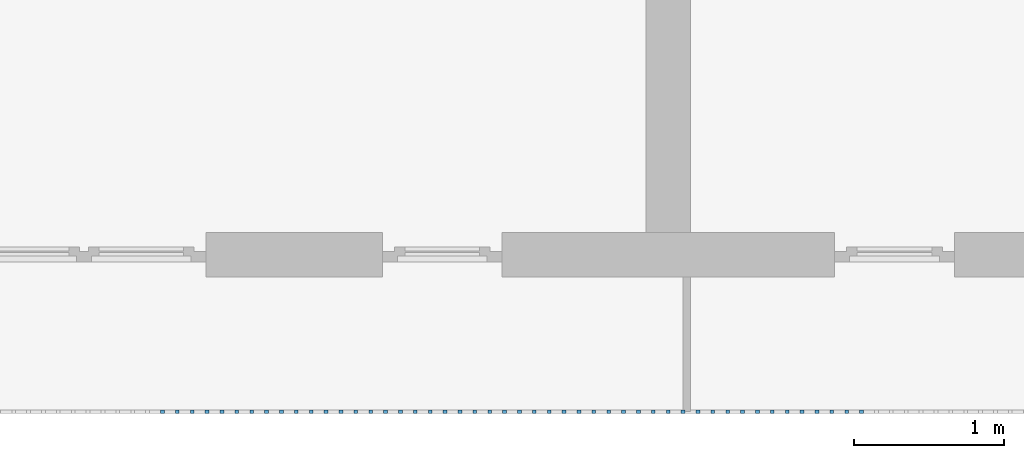
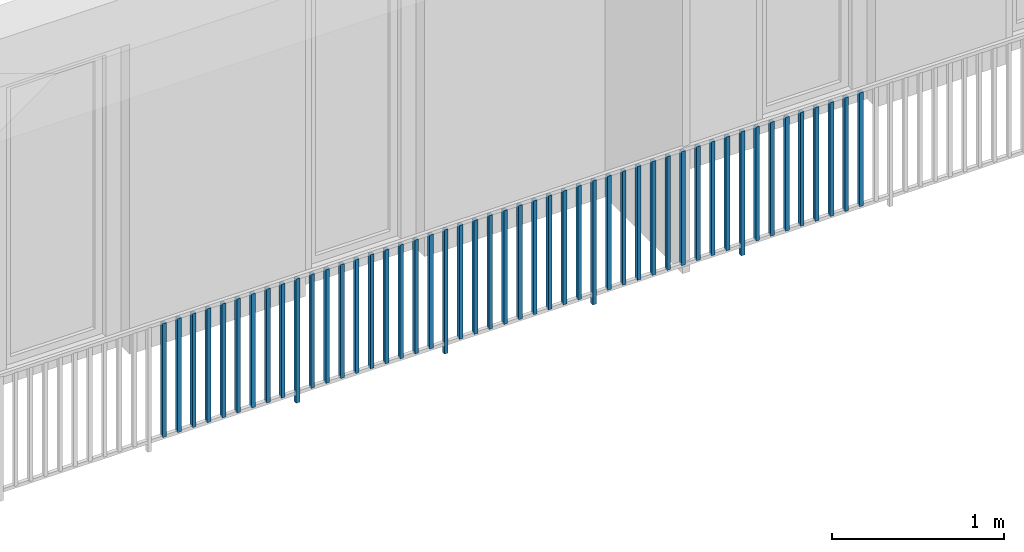
# One storey, part 35 of 54: 48 building element parts, 1 element without a shape of its own.
"""IFC4 building model written with IfcOpenShell, lengths in metres."""

import ifcopenshell
import ifcopenshell.guid

model = None  # the IFC model being written
_history = None  # IfcOwnerHistory: only IFC2X3 demands one
_inside = {}  # id of a spatial element -> (the spatial element, [elements in it])
_under = {}  # id of a project, library or spatial element -> (it, [spatial elements below it])
_declared = {}  # id of a project -> (the project, [libraries it declares])
_typed = {}  # id of a type object -> (the type object, [elements of that type])
_made_of = {}  # id of a material, layer set ... -> (it, [elements and type objects made of it])


def new_model(schema):
    """Start an empty IFC model of exactly this schema.

    Asked for "IFC4X3", IfcOpenShell would pick the latest addendum, in which some entities
    have other attributes; the version numbers below select the first issue.
    IFC2X3 requires an IfcOwnerHistory on every rooted entity: one is made here for all.
    """
    global model, _history
    if schema == "IFC4X3":
        model = ifcopenshell.file(schema_version=(4, 3, 0, 0))
    else:
        model = ifcopenshell.file(schema=schema)
    _inside.clear()
    _under.clear()
    _declared.clear()
    _typed.clear()
    _made_of.clear()
    _history = None
    if model.schema == "IFC2X3":
        org = make("IfcOrganization", Name="unknown")
        user = make(
            "IfcPersonAndOrganization",
            ThePerson=make("IfcPerson", FamilyName="unknown"),
            TheOrganization=org,
        )
        app = make(
            "IfcApplication",
            ApplicationDeveloper=org,
            Version="unknown",
            ApplicationFullName="unknown",
            ApplicationIdentifier="unknown",
        )
        _history = make(
            "IfcOwnerHistory",
            OwningUser=user,
            OwningApplication=app,
            ChangeAction="ADDED",
            CreationDate=0,
        )
    return model


def make(cls, **values):
    """One entity of the class cls with the attributes given. An attribute that is None is left unset."""
    return model.create_entity(
        cls, **{name: value for name, value in values.items() if value is not None}
    )


def entity(cls, *values):
    """Any entity or typed value of the class cls, its attributes in the order of the schema. None: left unset."""
    e = model.create_entity(cls)
    for i, value in enumerate(values):
        if value is not None:
            e[i] = value
    return e


def rooted(cls, **values):
    """An entity with a GlobalId (a new one), such as an element, a storey or a relation."""
    return make(cls, GlobalId=ifcopenshell.guid.new(), OwnerHistory=_history, **values)


def si_unit(unit_type, name, prefix=None):
    """IfcSIUnit, for example si_unit("LENGTHUNIT", "METRE", prefix="MILLI")."""
    return make("IfcSIUnit", UnitType=unit_type, Prefix=prefix, Name=name)


def converted_unit(unit_type, name, factor, base, dimensions=None, offset=None):
    """IfcConversionBasedUnit, such as the inch: factor (a typed value) times the base unit."""
    return make(
        "IfcConversionBasedUnit"
        if offset is None
        else "IfcConversionBasedUnitWithOffset",
        ConversionOffset=offset,
        Dimensions=None
        if dimensions is None
        else entity("IfcDimensionalExponents", *dimensions),
        UnitType=unit_type,
        Name=name,
        ConversionFactor=make(
            "IfcMeasureWithUnit", ValueComponent=factor, UnitComponent=base
        ),
    )


def derived_unit(unit_type, elements):
    """IfcDerivedUnit: a product of units, each with its exponent."""
    return make(
        "IfcDerivedUnit",
        Elements=[
            make("IfcDerivedUnitElement", Unit=unit, Exponent=power)
            for unit, power in elements
        ],
        UnitType=unit_type,
    )


def assignment(units):
    """IfcUnitAssignment: the units of a project."""
    return None if units is None else make("IfcUnitAssignment", Units=units)


def point(xyz):
    """IfcCartesianPoint."""
    return None if xyz is None else make("IfcCartesianPoint", Coordinates=xyz)


def direction(xyz):
    """IfcDirection."""
    return None if xyz is None else make("IfcDirection", DirectionRatios=xyz)


def frame(location, z_axis=None, x_axis=None):
    """IfcAxis2Placement3D, a coordinate frame: its origin and axes. An axis left out is left unset."""
    return make(
        "IfcAxis2Placement3D",
        Location=point(location),
        Axis=direction(z_axis),
        RefDirection=direction(x_axis),
    )


def origin_with_axes():
    """The frame at (0, 0, 0) with the z axis (0, 0, 1) and the x axis (1, 0, 0) written out."""
    return frame((0.0, 0.0, 0.0), z_axis=(0.0, 0.0, 1.0), x_axis=(1.0, 0.0, 0.0))


def place(relative_to, where):
    """IfcLocalPlacement: puts the frame where relative to a parent placement (None: the world)."""
    return make(
        "IfcLocalPlacement", PlacementRelTo=relative_to, RelativePlacement=where
    )


def context(
    kind, dimensions, precision=None, world=None, true_north=None, identifier=None
):
    """IfcGeometricRepresentationContext, for example the 3D "Model" context."""
    return make(
        "IfcGeometricRepresentationContext",
        ContextIdentifier=identifier,
        ContextType=kind,
        CoordinateSpaceDimension=dimensions,
        Precision=precision,
        WorldCoordinateSystem=world,
        TrueNorth=true_north,
    )


def subcontext(parent, identifier, kind, view, scale=None):
    """IfcGeometricRepresentationSubContext, for example "Body" below "Model"."""
    return make(
        "IfcGeometricRepresentationSubContext",
        ContextIdentifier=identifier,
        ContextType=kind,
        ParentContext=parent,
        TargetScale=scale,
        TargetView=view,
    )


def project(units=None, contexts=None):
    """IfcProject with its units and contexts."""
    return rooted(
        "IfcProject",
        Name="project",
        RepresentationContexts=contexts,
        UnitsInContext=assignment(units),
    )


def spatial(cls, under=None, at=None, **own):
    """A site, building, storey or space (cls), placed at a placement, below another one or the project."""
    s = rooted(cls, ObjectPlacement=at, **own)
    if under is not None:
        _under.setdefault(under.id(), (under, []))[1].append(s)
    return s


def point_list(points):
    """IfcCartesianPointList2D or 3D."""
    cls = (
        "IfcCartesianPointList2D" if len(points[0]) == 2 else "IfcCartesianPointList3D"
    )
    return make(cls, CoordList=points)


def polygons(points, faces, closed=None, point_numbers=None):
    """IfcPolygonalFaceSet: a face is its outer loop, then its inner loops; points numbered from 1."""
    made = []
    for loops in faces:
        if len(loops) == 1:
            made.append(make("IfcIndexedPolygonalFace", CoordIndex=loops[0]))
        else:
            made.append(
                make(
                    "IfcIndexedPolygonalFaceWithVoids",
                    CoordIndex=loops[0],
                    InnerCoordIndices=loops[1:],
                )
            )
    return make(
        "IfcPolygonalFaceSet",
        Coordinates=point_list(points),
        Closed=closed,
        Faces=made,
        PnIndex=point_numbers,
    )


def shape(context_of_items, identifier, shape_type, items):
    """IfcShapeRepresentation: the items that make up one representation, for example the "Body"."""
    return make(
        "IfcShapeRepresentation",
        ContextOfItems=context_of_items,
        RepresentationIdentifier=identifier,
        RepresentationType=shape_type,
        Items=items,
    )


def material(Name=None, Category=None):
    """IfcMaterial."""
    return make("IfcMaterial", Name=Name, Category=Category)


def made_of(thing, what):
    """Note that an element or type object is made of a material, layer set ...; save() writes the relation."""
    if what is not None:
        _made_of.setdefault(what.id(), (what, []))[1].append(thing)
    return thing


def type_object(cls, material=None, **own):
    """A type object (cls), such as IfcWallType, which elements share."""
    return made_of(rooted(cls, **own), material)


def element(
    cls,
    number,
    at=None,
    inside=None,
    cuts=None,
    type_object=None,
    material=None,
    context=None,
    identifier="Body",
    shape_type=None,
    held_by="IfcProductDefinitionShape",
    body=None,
    shapes=None,
    **own,
):
    """One element of the class cls, such as IfcWall. Its Tag is "e" and its number.

    at: its placement. inside: the storey or other place that contains it. cuts: it is an
    opening in that element (IfcRelVoidsElement). A single representation is given by context,
    identifier, shape_type and body (its items); several are given by shapes. held_by: the class
    of the entity that holds the representations. save() writes the other relations.
    """
    e = rooted(cls, Tag="e%d" % number, ObjectPlacement=at, **own)
    if body is not None:
        shapes = [shape(context, identifier, shape_type, body)]
    if shapes is not None:
        e.Representation = make(held_by, Representations=shapes)
    if inside is not None:
        _inside.setdefault(inside.id(), (inside, []))[1].append(e)
    if cuts is not None:
        rooted(
            "IfcRelVoidsElement", RelatingBuildingElement=cuts, RelatedOpeningElement=e
        )
    if type_object is not None:
        _typed.setdefault(type_object.id(), (type_object, []))[1].append(e)
    return made_of(e, material)


def aggregate(whole, parts):
    """IfcRelAggregates: a whole, such as a stair, and the parts it consists of."""
    return rooted("IfcRelAggregates", RelatingObject=whole, RelatedObjects=parts)


def save(model, path):
    """Write the relations noted so far, then the file.

    IfcRelAggregates (storeys below a building ...), IfcRelContainedInSpatialStructure (elements
    in a storey), IfcRelDefinesByType, IfcRelAssociatesMaterial and IfcRelDeclares: one each for
    every whole, place, type object, material and project.
    """
    for whole, parts in _under.values():
        aggregate(whole, parts)
    for where, things in _inside.values():
        rooted(
            "IfcRelContainedInSpatialStructure",
            RelatedElements=things,
            RelatingStructure=where,
        )
    for kind, things in _typed.values():
        rooted("IfcRelDefinesByType", RelatedObjects=things, RelatingType=kind)
    for what, things in _made_of.values():
        rooted("IfcRelAssociatesMaterial", RelatedObjects=things, RelatingMaterial=what)
    for by, libraries in _declared.values():
        rooted("IfcRelDeclares", RelatingContext=by, RelatedDefinitions=libraries)
    model.write(path)


model = new_model("IFC4")

# Units and contexts
model_context = context("Model", 3, precision=1e-05, world=origin_with_axes(), true_north=direction((0.0, 1.0)))
body_context = subcontext(model_context, "Body", "Model", "MODEL_VIEW")
ifc_project = project(units=[si_unit("LENGTHUNIT", "METRE"), si_unit("AREAUNIT", "SQUARE_METRE"), si_unit("VOLUMEUNIT", "CUBIC_METRE"), converted_unit("PLANEANGLEUNIT", "DEGREE", entity("IfcPlaneAngleMeasure", 0.0174532925199), si_unit("PLANEANGLEUNIT", "RADIAN"), dimensions=[0, 0, 0, 0, 0, 0, 0]), converted_unit("TIMEUNIT", "Year", entity("IfcTimeMeasure", 31556926.0), si_unit("TIMEUNIT", "SECOND"), dimensions=[0, 0, 1, 0, 0, 0, 0]), si_unit("MASSUNIT", "GRAM", prefix="KILO"), si_unit("THERMODYNAMICTEMPERATUREUNIT", "DEGREE_CELSIUS"), si_unit("LUMINOUSINTENSITYUNIT", "LUMEN"), si_unit("ENERGYUNIT", "JOULE", prefix="MEGA"), derived_unit("THERMALCONDUCTANCEUNIT", [(si_unit("POWERUNIT", "WATT"), 1), (si_unit("LENGTHUNIT", "METRE"), -1), (si_unit("THERMODYNAMICTEMPERATUREUNIT", "KELVIN"), -1)]), derived_unit("SPECIFICHEATCAPACITYUNIT", [(si_unit("ENERGYUNIT", "JOULE"), 1), (si_unit("MASSUNIT", "GRAM", prefix="KILO"), -1), (si_unit("THERMODYNAMICTEMPERATUREUNIT", "KELVIN"), -1)]), derived_unit("MASSDENSITYUNIT", [(si_unit("MASSUNIT", "GRAM", prefix="KILO"), 1), (si_unit("VOLUMEUNIT", "CUBIC_METRE"), -1)])], contexts=[model_context])

# Site, building, storey, space
site_placement = place(None, origin_with_axes())
site = spatial("IfcSite", under=ifc_project, at=site_placement, CompositionType="ELEMENT")
building_placement = place(site_placement, origin_with_axes())
building = spatial("IfcBuilding", under=site, at=building_placement, CompositionType="ELEMENT")
storey_placement = place(building_placement, frame((0.0, 0.0, 6.29), z_axis=(0.0, 0.0, 1.0), x_axis=(1.0, 0.0, 0.0)))
storey = spatial("IfcBuildingStorey", under=building, at=storey_placement, Name="2. Geschoss", CompositionType="ELEMENT", Elevation=6.29)
space_placement = place(storey_placement, frame((10.2378006196, 9.82118769833, 0.0), z_axis=(0.0, 0.0, 1.0), x_axis=(-1.0, 0.0, 0.0)))
space = spatial("IfcSpace", under=storey, at=space_placement, CompositionType="ELEMENT", PredefinedType="EXTERNAL")

# Railing, building element parts
railing_type = type_object("IfcRailingType", PredefinedType="NOTDEFINED")
railing_placement = place(space_placement, frame((0.0, -7.06315681498e-08, 0.0), z_axis=(0.0, 0.0, 1.0), x_axis=(-1.0, 0.0, 0.0)))
railing = element("IfcRailing", 1, at=railing_placement, inside=space, type_object=railing_type, PredefinedType="NOTDEFINED")
ifc_material = material()
building_element_part_1_placement = place(railing_placement, origin_with_axes())
building_element_part_1 = element("IfcBuildingElementPart", 2, at=building_element_part_1_placement, material=ifc_material, PredefinedType="NOTDEFINED", context=body_context, shape_type="Tessellation", body=[
    polygons([(-14.8097608696, -20.6625, 0.07), (-14.8097608696, -20.6375, 0.07), (-14.8097608696, -20.6375, 0.8775), (-14.8097608696, -20.6625, 0.8775), (-14.8347608696, -20.6625, 0.07), (-14.8347608696, -20.6375, 0.07), (-14.8347608696, -20.6375, 0.8775), (-14.8347608696, -20.6625, 0.8775)], [[[1, 2, 3, 4]], [[1, 5, 6, 2]], [[2, 6, 7, 3]], [[4, 3, 7, 8]], [[5, 1, 4, 8]], [[6, 5, 8, 7]]], closed=True),
])
building_element_part_2_placement = place(railing_placement, origin_with_axes())
building_element_part_2 = element("IfcBuildingElementPart", 3, at=building_element_part_2_placement, material=ifc_material, PredefinedType="NOTDEFINED", context=body_context, shape_type="Tessellation", body=[
    polygons([(-14.7102826087, -20.6625, 0.07), (-14.7102826087, -20.6375, 0.07), (-14.7102826087, -20.6375, 0.8775), (-14.7102826087, -20.6625, 0.8775), (-14.7352826087, -20.6625, 0.07), (-14.7352826087, -20.6375, 0.07), (-14.7352826087, -20.6375, 0.8775), (-14.7352826087, -20.6625, 0.8775)], [[[1, 2, 3, 4]], [[1, 5, 6, 2]], [[2, 6, 7, 3]], [[4, 3, 7, 8]], [[5, 1, 4, 8]], [[6, 5, 8, 7]]], closed=True),
])
building_element_part_3_placement = place(railing_placement, origin_with_axes())
building_element_part_3 = element("IfcBuildingElementPart", 4, at=building_element_part_3_placement, material=ifc_material, PredefinedType="NOTDEFINED", context=body_context, shape_type="Tessellation", body=[
    polygons([(-14.6108043478, -20.6625, 0.07), (-14.6108043478, -20.6375, 0.07), (-14.6108043478, -20.6375, 0.8775), (-14.6108043478, -20.6625, 0.8775), (-14.6358043478, -20.6625, 0.07), (-14.6358043478, -20.6375, 0.07), (-14.6358043478, -20.6375, 0.8775), (-14.6358043478, -20.6625, 0.8775)], [[[1, 2, 3, 4]], [[1, 5, 6, 2]], [[2, 6, 7, 3]], [[4, 3, 7, 8]], [[5, 1, 4, 8]], [[6, 5, 8, 7]]], closed=True),
])
building_element_part_4_placement = place(railing_placement, origin_with_axes())
building_element_part_4 = element("IfcBuildingElementPart", 5, at=building_element_part_4_placement, material=ifc_material, PredefinedType="NOTDEFINED", context=body_context, shape_type="Tessellation", body=[
    polygons([(-14.511326087, -20.6625, 0.07), (-14.511326087, -20.6375, 0.07), (-14.511326087, -20.6375, 0.8775), (-14.511326087, -20.6625, 0.8775), (-14.536326087, -20.6625, 0.07), (-14.536326087, -20.6375, 0.07), (-14.536326087, -20.6375, 0.8775), (-14.536326087, -20.6625, 0.8775)], [[[1, 2, 3, 4]], [[1, 5, 6, 2]], [[2, 6, 7, 3]], [[4, 3, 7, 8]], [[5, 1, 4, 8]], [[6, 5, 8, 7]]], closed=True),
])
building_element_part_5_placement = place(railing_placement, origin_with_axes())
building_element_part_5 = element("IfcBuildingElementPart", 6, at=building_element_part_5_placement, material=ifc_material, PredefinedType="NOTDEFINED", context=body_context, shape_type="Tessellation", body=[
    polygons([(-14.4118478261, -20.6625, 0.07), (-14.4118478261, -20.6375, 0.07), (-14.4118478261, -20.6375, 0.8775), (-14.4118478261, -20.6625, 0.8775), (-14.4368478261, -20.6625, 0.07), (-14.4368478261, -20.6375, 0.07), (-14.4368478261, -20.6375, 0.8775), (-14.4368478261, -20.6625, 0.8775)], [[[1, 2, 3, 4]], [[1, 5, 6, 2]], [[2, 6, 7, 3]], [[4, 3, 7, 8]], [[5, 1, 4, 8]], [[6, 5, 8, 7]]], closed=True),
])
building_element_part_6_placement = place(railing_placement, origin_with_axes())
building_element_part_6 = element("IfcBuildingElementPart", 7, at=building_element_part_6_placement, material=ifc_material, PredefinedType="NOTDEFINED", context=body_context, shape_type="Tessellation", body=[
    polygons([(-14.3123695652, -20.6625, 0.07), (-14.3123695652, -20.6375, 0.07), (-14.3123695652, -20.6375, 0.8775), (-14.3123695652, -20.6625, 0.8775), (-14.3373695652, -20.6625, 0.07), (-14.3373695652, -20.6375, 0.07), (-14.3373695652, -20.6375, 0.8775), (-14.3373695652, -20.6625, 0.8775)], [[[1, 2, 3, 4]], [[1, 5, 6, 2]], [[2, 6, 7, 3]], [[4, 3, 7, 8]], [[5, 1, 4, 8]], [[6, 5, 8, 7]]], closed=True),
])
building_element_part_7_placement = place(railing_placement, origin_with_axes())
building_element_part_7 = element("IfcBuildingElementPart", 8, at=building_element_part_7_placement, material=ifc_material, PredefinedType="NOTDEFINED", context=body_context, shape_type="Tessellation", body=[
    polygons([(-14.2128913043, -20.6625, 0.07), (-14.2128913043, -20.6375, 0.07), (-14.2128913043, -20.6375, 0.8775), (-14.2128913043, -20.6625, 0.8775), (-14.2378913043, -20.6625, 0.07), (-14.2378913043, -20.6375, 0.07), (-14.2378913043, -20.6375, 0.8775), (-14.2378913043, -20.6625, 0.8775)], [[[1, 2, 3, 4]], [[1, 5, 6, 2]], [[2, 6, 7, 3]], [[4, 3, 7, 8]], [[5, 1, 4, 8]], [[6, 5, 8, 7]]], closed=True),
])
building_element_part_8_placement = place(railing_placement, origin_with_axes())
building_element_part_8 = element("IfcBuildingElementPart", 9, at=building_element_part_8_placement, material=ifc_material, PredefinedType="NOTDEFINED", context=body_context, shape_type="Tessellation", body=[
    polygons([(-14.1134130435, -20.6625, 0.07), (-14.1134130435, -20.6375, 0.07), (-14.1134130435, -20.6375, 0.8775), (-14.1134130435, -20.6625, 0.8775), (-14.1384130435, -20.6625, 0.07), (-14.1384130435, -20.6375, 0.07), (-14.1384130435, -20.6375, 0.8775), (-14.1384130435, -20.6625, 0.8775)], [[[1, 2, 3, 4]], [[1, 5, 6, 2]], [[2, 6, 7, 3]], [[4, 3, 7, 8]], [[5, 1, 4, 8]], [[6, 5, 8, 7]]], closed=True),
])
building_element_part_9_placement = place(railing_placement, origin_with_axes())
building_element_part_9 = element("IfcBuildingElementPart", 10, at=building_element_part_9_placement, material=ifc_material, PredefinedType="NOTDEFINED", context=body_context, shape_type="Tessellation", body=[
    polygons([(-14.0139347826, -20.6625, 0.07), (-14.0139347826, -20.6375, 0.07), (-14.0139347826, -20.6375, 0.8775), (-14.0139347826, -20.6625, 0.8775), (-14.0389347826, -20.6625, 0.07), (-14.0389347826, -20.6375, 0.07), (-14.0389347826, -20.6375, 0.8775), (-14.0389347826, -20.6625, 0.8775)], [[[1, 2, 3, 4]], [[1, 5, 6, 2]], [[2, 6, 7, 3]], [[4, 3, 7, 8]], [[5, 1, 4, 8]], [[6, 5, 8, 7]]], closed=True),
])
building_element_part_10_placement = place(railing_placement, origin_with_axes())
building_element_part_10 = element("IfcBuildingElementPart", 11, at=building_element_part_10_placement, material=ifc_material, PredefinedType="NOTDEFINED", context=body_context, shape_type="Tessellation", body=[
    polygons([(-13.9144565217, -20.6625, 0.0), (-13.9144565217, -20.6375, 0.0), (-13.9144565217, -20.6375, 0.88), (-13.9144565217, -20.6625, 0.88), (-13.9394565217, -20.6625, 0.0), (-13.9394565217, -20.6375, 0.0), (-13.9394565217, -20.6375, 0.88), (-13.9394565217, -20.6625, 0.88)], [[[1, 2, 3, 4]], [[1, 5, 6, 2]], [[2, 6, 7, 3]], [[4, 3, 7, 8]], [[5, 1, 4, 8]], [[6, 5, 8, 7]]], closed=True),
])
building_element_part_11_placement = place(railing_placement, origin_with_axes())
building_element_part_11 = element("IfcBuildingElementPart", 12, at=building_element_part_11_placement, material=ifc_material, PredefinedType="NOTDEFINED", context=body_context, shape_type="Tessellation", body=[
    polygons([(-13.8149782609, -20.6625, 0.07), (-13.8149782609, -20.6375, 0.07), (-13.8149782609, -20.6375, 0.8775), (-13.8149782609, -20.6625, 0.8775), (-13.8399782609, -20.6625, 0.07), (-13.8399782609, -20.6375, 0.07), (-13.8399782609, -20.6375, 0.8775), (-13.8399782609, -20.6625, 0.8775)], [[[1, 2, 3, 4]], [[1, 5, 6, 2]], [[2, 6, 7, 3]], [[4, 3, 7, 8]], [[5, 1, 4, 8]], [[6, 5, 8, 7]]], closed=True),
])
building_element_part_12_placement = place(railing_placement, origin_with_axes())
building_element_part_12 = element("IfcBuildingElementPart", 13, at=building_element_part_12_placement, material=ifc_material, PredefinedType="NOTDEFINED", context=body_context, shape_type="Tessellation", body=[
    polygons([(-13.7155, -20.6625, 0.07), (-13.7155, -20.6375, 0.07), (-13.7155, -20.6375, 0.8775), (-13.7155, -20.6625, 0.8775), (-13.7405, -20.6625, 0.07), (-13.7405, -20.6375, 0.07), (-13.7405, -20.6375, 0.8775), (-13.7405, -20.6625, 0.8775)], [[[1, 2, 3, 4]], [[1, 5, 6, 2]], [[2, 6, 7, 3]], [[4, 3, 7, 8]], [[5, 1, 4, 8]], [[6, 5, 8, 7]]], closed=True),
])
building_element_part_13_placement = place(railing_placement, origin_with_axes())
building_element_part_13 = element("IfcBuildingElementPart", 14, at=building_element_part_13_placement, material=ifc_material, PredefinedType="NOTDEFINED", context=body_context, shape_type="Tessellation", body=[
    polygons([(-13.6160217391, -20.6625, 0.07), (-13.6160217391, -20.6375, 0.07), (-13.6160217391, -20.6375, 0.8775), (-13.6160217391, -20.6625, 0.8775), (-13.6410217391, -20.6625, 0.07), (-13.6410217391, -20.6375, 0.07), (-13.6410217391, -20.6375, 0.8775), (-13.6410217391, -20.6625, 0.8775)], [[[1, 2, 3, 4]], [[1, 5, 6, 2]], [[2, 6, 7, 3]], [[4, 3, 7, 8]], [[5, 1, 4, 8]], [[6, 5, 8, 7]]], closed=True),
])
building_element_part_14_placement = place(railing_placement, origin_with_axes())
building_element_part_14 = element("IfcBuildingElementPart", 15, at=building_element_part_14_placement, material=ifc_material, PredefinedType="NOTDEFINED", context=body_context, shape_type="Tessellation", body=[
    polygons([(-13.5165434783, -20.6625, 0.07), (-13.5165434783, -20.6375, 0.07), (-13.5165434783, -20.6375, 0.8775), (-13.5165434783, -20.6625, 0.8775), (-13.5415434783, -20.6625, 0.07), (-13.5415434783, -20.6375, 0.07), (-13.5415434783, -20.6375, 0.8775), (-13.5415434783, -20.6625, 0.8775)], [[[1, 2, 3, 4]], [[1, 5, 6, 2]], [[2, 6, 7, 3]], [[4, 3, 7, 8]], [[5, 1, 4, 8]], [[6, 5, 8, 7]]], closed=True),
])
building_element_part_15_placement = place(railing_placement, origin_with_axes())
building_element_part_15 = element("IfcBuildingElementPart", 16, at=building_element_part_15_placement, material=ifc_material, PredefinedType="NOTDEFINED", context=body_context, shape_type="Tessellation", body=[
    polygons([(-13.4170652174, -20.6625, 0.07), (-13.4170652174, -20.6375, 0.07), (-13.4170652174, -20.6375, 0.8775), (-13.4170652174, -20.6625, 0.8775), (-13.4420652174, -20.6625, 0.07), (-13.4420652174, -20.6375, 0.07), (-13.4420652174, -20.6375, 0.8775), (-13.4420652174, -20.6625, 0.8775)], [[[1, 2, 3, 4]], [[1, 5, 6, 2]], [[2, 6, 7, 3]], [[4, 3, 7, 8]], [[5, 1, 4, 8]], [[6, 5, 8, 7]]], closed=True),
])
building_element_part_16_placement = place(railing_placement, origin_with_axes())
building_element_part_16 = element("IfcBuildingElementPart", 17, at=building_element_part_16_placement, material=ifc_material, PredefinedType="NOTDEFINED", context=body_context, shape_type="Tessellation", body=[
    polygons([(-13.3175869565, -20.6625, 0.07), (-13.3175869565, -20.6375, 0.07), (-13.3175869565, -20.6375, 0.8775), (-13.3175869565, -20.6625, 0.8775), (-13.3425869565, -20.6625, 0.07), (-13.3425869565, -20.6375, 0.07), (-13.3425869565, -20.6375, 0.8775), (-13.3425869565, -20.6625, 0.8775)], [[[1, 2, 3, 4]], [[1, 5, 6, 2]], [[2, 6, 7, 3]], [[4, 3, 7, 8]], [[5, 1, 4, 8]], [[6, 5, 8, 7]]], closed=True),
])
building_element_part_17_placement = place(railing_placement, origin_with_axes())
building_element_part_17 = element("IfcBuildingElementPart", 18, at=building_element_part_17_placement, material=ifc_material, PredefinedType="NOTDEFINED", context=body_context, shape_type="Tessellation", body=[
    polygons([(-13.2181086957, -20.6625, 0.07), (-13.2181086957, -20.6375, 0.07), (-13.2181086957, -20.6375, 0.8775), (-13.2181086957, -20.6625, 0.8775), (-13.2431086957, -20.6625, 0.07), (-13.2431086957, -20.6375, 0.07), (-13.2431086957, -20.6375, 0.8775), (-13.2431086957, -20.6625, 0.8775)], [[[1, 2, 3, 4]], [[1, 5, 6, 2]], [[2, 6, 7, 3]], [[4, 3, 7, 8]], [[5, 1, 4, 8]], [[6, 5, 8, 7]]], closed=True),
])
building_element_part_18_placement = place(railing_placement, origin_with_axes())
building_element_part_18 = element("IfcBuildingElementPart", 19, at=building_element_part_18_placement, material=ifc_material, PredefinedType="NOTDEFINED", context=body_context, shape_type="Tessellation", body=[
    polygons([(-13.1186304348, -20.6625, 0.07), (-13.1186304348, -20.6375, 0.07), (-13.1186304348, -20.6375, 0.8775), (-13.1186304348, -20.6625, 0.8775), (-13.1436304348, -20.6625, 0.07), (-13.1436304348, -20.6375, 0.07), (-13.1436304348, -20.6375, 0.8775), (-13.1436304348, -20.6625, 0.8775)], [[[1, 2, 3, 4]], [[1, 5, 6, 2]], [[2, 6, 7, 3]], [[4, 3, 7, 8]], [[5, 1, 4, 8]], [[6, 5, 8, 7]]], closed=True),
])
building_element_part_19_placement = place(railing_placement, origin_with_axes())
building_element_part_19 = element("IfcBuildingElementPart", 20, at=building_element_part_19_placement, material=ifc_material, PredefinedType="NOTDEFINED", context=body_context, shape_type="Tessellation", body=[
    polygons([(-13.0191521739, -20.6625, 0.07), (-13.0191521739, -20.6375, 0.07), (-13.0191521739, -20.6375, 0.8775), (-13.0191521739, -20.6625, 0.8775), (-13.0441521739, -20.6625, 0.07), (-13.0441521739, -20.6375, 0.07), (-13.0441521739, -20.6375, 0.8775), (-13.0441521739, -20.6625, 0.8775)], [[[1, 2, 3, 4]], [[1, 5, 6, 2]], [[2, 6, 7, 3]], [[4, 3, 7, 8]], [[5, 1, 4, 8]], [[6, 5, 8, 7]]], closed=True),
])
building_element_part_20_placement = place(railing_placement, origin_with_axes())
building_element_part_20 = element("IfcBuildingElementPart", 21, at=building_element_part_20_placement, material=ifc_material, PredefinedType="NOTDEFINED", context=body_context, shape_type="Tessellation", body=[
    polygons([(-12.919673913, -20.6625, 0.0), (-12.919673913, -20.6375, 0.0), (-12.919673913, -20.6375, 0.88), (-12.919673913, -20.6625, 0.88), (-12.944673913, -20.6625, 0.0), (-12.944673913, -20.6375, 0.0), (-12.944673913, -20.6375, 0.88), (-12.944673913, -20.6625, 0.88)], [[[1, 2, 3, 4]], [[1, 5, 6, 2]], [[2, 6, 7, 3]], [[4, 3, 7, 8]], [[5, 1, 4, 8]], [[6, 5, 8, 7]]], closed=True),
])
building_element_part_21_placement = place(railing_placement, origin_with_axes())
building_element_part_21 = element("IfcBuildingElementPart", 22, at=building_element_part_21_placement, material=ifc_material, PredefinedType="NOTDEFINED", context=body_context, shape_type="Tessellation", body=[
    polygons([(-12.8201956522, -20.6625, 0.07), (-12.8201956522, -20.6375, 0.07), (-12.8201956522, -20.6375, 0.8775), (-12.8201956522, -20.6625, 0.8775), (-12.8451956522, -20.6625, 0.07), (-12.8451956522, -20.6375, 0.07), (-12.8451956522, -20.6375, 0.8775), (-12.8451956522, -20.6625, 0.8775)], [[[1, 2, 3, 4]], [[1, 5, 6, 2]], [[2, 6, 7, 3]], [[4, 3, 7, 8]], [[5, 1, 4, 8]], [[6, 5, 8, 7]]], closed=True),
])
building_element_part_22_placement = place(railing_placement, origin_with_axes())
building_element_part_22 = element("IfcBuildingElementPart", 23, at=building_element_part_22_placement, material=ifc_material, PredefinedType="NOTDEFINED", context=body_context, shape_type="Tessellation", body=[
    polygons([(-12.7207173913, -20.6625, 0.07), (-12.7207173913, -20.6375, 0.07), (-12.7207173913, -20.6375, 0.8775), (-12.7207173913, -20.6625, 0.8775), (-12.7457173913, -20.6625, 0.07), (-12.7457173913, -20.6375, 0.07), (-12.7457173913, -20.6375, 0.8775), (-12.7457173913, -20.6625, 0.8775)], [[[1, 2, 3, 4]], [[1, 5, 6, 2]], [[2, 6, 7, 3]], [[4, 3, 7, 8]], [[5, 1, 4, 8]], [[6, 5, 8, 7]]], closed=True),
])
building_element_part_23_placement = place(railing_placement, origin_with_axes())
building_element_part_23 = element("IfcBuildingElementPart", 24, at=building_element_part_23_placement, material=ifc_material, PredefinedType="NOTDEFINED", context=body_context, shape_type="Tessellation", body=[
    polygons([(-12.6212391304, -20.6625, 0.07), (-12.6212391304, -20.6375, 0.07), (-12.6212391304, -20.6375, 0.8775), (-12.6212391304, -20.6625, 0.8775), (-12.6462391304, -20.6625, 0.07), (-12.6462391304, -20.6375, 0.07), (-12.6462391304, -20.6375, 0.8775), (-12.6462391304, -20.6625, 0.8775)], [[[1, 2, 3, 4]], [[1, 5, 6, 2]], [[2, 6, 7, 3]], [[4, 3, 7, 8]], [[5, 1, 4, 8]], [[6, 5, 8, 7]]], closed=True),
])
building_element_part_24_placement = place(railing_placement, origin_with_axes())
building_element_part_24 = element("IfcBuildingElementPart", 25, at=building_element_part_24_placement, material=ifc_material, PredefinedType="NOTDEFINED", context=body_context, shape_type="Tessellation", body=[
    polygons([(-12.5217608696, -20.6625, 0.07), (-12.5217608696, -20.6375, 0.07), (-12.5217608696, -20.6375, 0.8775), (-12.5217608696, -20.6625, 0.8775), (-12.5467608696, -20.6625, 0.07), (-12.5467608696, -20.6375, 0.07), (-12.5467608696, -20.6375, 0.8775), (-12.5467608696, -20.6625, 0.8775)], [[[1, 2, 3, 4]], [[1, 5, 6, 2]], [[2, 6, 7, 3]], [[4, 3, 7, 8]], [[5, 1, 4, 8]], [[6, 5, 8, 7]]], closed=True),
])
building_element_part_25_placement = place(railing_placement, origin_with_axes())
building_element_part_25 = element("IfcBuildingElementPart", 26, at=building_element_part_25_placement, material=ifc_material, PredefinedType="NOTDEFINED", context=body_context, shape_type="Tessellation", body=[
    polygons([(-12.4222826087, -20.6625, 0.07), (-12.4222826087, -20.6375, 0.07), (-12.4222826087, -20.6375, 0.8775), (-12.4222826087, -20.6625, 0.8775), (-12.4472826087, -20.6625, 0.07), (-12.4472826087, -20.6375, 0.07), (-12.4472826087, -20.6375, 0.8775), (-12.4472826087, -20.6625, 0.8775)], [[[1, 2, 3, 4]], [[1, 5, 6, 2]], [[2, 6, 7, 3]], [[4, 3, 7, 8]], [[5, 1, 4, 8]], [[6, 5, 8, 7]]], closed=True),
])
building_element_part_26_placement = place(railing_placement, origin_with_axes())
building_element_part_26 = element("IfcBuildingElementPart", 27, at=building_element_part_26_placement, material=ifc_material, PredefinedType="NOTDEFINED", context=body_context, shape_type="Tessellation", body=[
    polygons([(-12.3228043478, -20.6625, 0.07), (-12.3228043478, -20.6375, 0.07), (-12.3228043478, -20.6375, 0.8775), (-12.3228043478, -20.6625, 0.8775), (-12.3478043478, -20.6625, 0.07), (-12.3478043478, -20.6375, 0.07), (-12.3478043478, -20.6375, 0.8775), (-12.3478043478, -20.6625, 0.8775)], [[[1, 2, 3, 4]], [[1, 5, 6, 2]], [[2, 6, 7, 3]], [[4, 3, 7, 8]], [[5, 1, 4, 8]], [[6, 5, 8, 7]]], closed=True),
])
building_element_part_27_placement = place(railing_placement, origin_with_axes())
building_element_part_27 = element("IfcBuildingElementPart", 28, at=building_element_part_27_placement, material=ifc_material, PredefinedType="NOTDEFINED", context=body_context, shape_type="Tessellation", body=[
    polygons([(-12.223326087, -20.6625, 0.07), (-12.223326087, -20.6375, 0.07), (-12.223326087, -20.6375, 0.8775), (-12.223326087, -20.6625, 0.8775), (-12.248326087, -20.6625, 0.07), (-12.248326087, -20.6375, 0.07), (-12.248326087, -20.6375, 0.8775), (-12.248326087, -20.6625, 0.8775)], [[[1, 2, 3, 4]], [[1, 5, 6, 2]], [[2, 6, 7, 3]], [[4, 3, 7, 8]], [[5, 1, 4, 8]], [[6, 5, 8, 7]]], closed=True),
])
building_element_part_28_placement = place(railing_placement, origin_with_axes())
building_element_part_28 = element("IfcBuildingElementPart", 29, at=building_element_part_28_placement, material=ifc_material, PredefinedType="NOTDEFINED", context=body_context, shape_type="Tessellation", body=[
    polygons([(-12.1238478261, -20.6625, 0.07), (-12.1238478261, -20.6375, 0.07), (-12.1238478261, -20.6375, 0.8775), (-12.1238478261, -20.6625, 0.8775), (-12.1488478261, -20.6625, 0.07), (-12.1488478261, -20.6375, 0.07), (-12.1488478261, -20.6375, 0.8775), (-12.1488478261, -20.6625, 0.8775)], [[[1, 2, 3, 4]], [[1, 5, 6, 2]], [[2, 6, 7, 3]], [[4, 3, 7, 8]], [[5, 1, 4, 8]], [[6, 5, 8, 7]]], closed=True),
])
building_element_part_29_placement = place(railing_placement, origin_with_axes())
building_element_part_29 = element("IfcBuildingElementPart", 30, at=building_element_part_29_placement, material=ifc_material, PredefinedType="NOTDEFINED", context=body_context, shape_type="Tessellation", body=[
    polygons([(-12.0243695652, -20.6625, 0.07), (-12.0243695652, -20.6375, 0.07), (-12.0243695652, -20.6375, 0.8775), (-12.0243695652, -20.6625, 0.8775), (-12.0493695652, -20.6625, 0.07), (-12.0493695652, -20.6375, 0.07), (-12.0493695652, -20.6375, 0.8775), (-12.0493695652, -20.6625, 0.8775)], [[[1, 2, 3, 4]], [[1, 5, 6, 2]], [[2, 6, 7, 3]], [[4, 3, 7, 8]], [[5, 1, 4, 8]], [[6, 5, 8, 7]]], closed=True),
])
building_element_part_30_placement = place(railing_placement, origin_with_axes())
building_element_part_30 = element("IfcBuildingElementPart", 31, at=building_element_part_30_placement, material=ifc_material, PredefinedType="NOTDEFINED", context=body_context, shape_type="Tessellation", body=[
    polygons([(-11.9248913043, -20.6625, 0.0), (-11.9248913043, -20.6375, 0.0), (-11.9248913043, -20.6375, 0.88), (-11.9248913043, -20.6625, 0.88), (-11.9498913043, -20.6625, 0.0), (-11.9498913043, -20.6375, 0.0), (-11.9498913043, -20.6375, 0.88), (-11.9498913043, -20.6625, 0.88)], [[[1, 2, 3, 4]], [[1, 5, 6, 2]], [[2, 6, 7, 3]], [[4, 3, 7, 8]], [[5, 1, 4, 8]], [[6, 5, 8, 7]]], closed=True),
])
building_element_part_31_placement = place(railing_placement, origin_with_axes())
building_element_part_31 = element("IfcBuildingElementPart", 32, at=building_element_part_31_placement, material=ifc_material, PredefinedType="NOTDEFINED", context=body_context, shape_type="Tessellation", body=[
    polygons([(-11.8254130435, -20.6625, 0.07), (-11.8254130435, -20.6375, 0.07), (-11.8254130435, -20.6375, 0.8775), (-11.8254130435, -20.6625, 0.8775), (-11.8504130435, -20.6625, 0.07), (-11.8504130435, -20.6375, 0.07), (-11.8504130435, -20.6375, 0.8775), (-11.8504130435, -20.6625, 0.8775)], [[[1, 2, 3, 4]], [[1, 5, 6, 2]], [[2, 6, 7, 3]], [[4, 3, 7, 8]], [[5, 1, 4, 8]], [[6, 5, 8, 7]]], closed=True),
])
building_element_part_32_placement = place(railing_placement, origin_with_axes())
building_element_part_32 = element("IfcBuildingElementPart", 33, at=building_element_part_32_placement, material=ifc_material, PredefinedType="NOTDEFINED", context=body_context, shape_type="Tessellation", body=[
    polygons([(-11.7259347826, -20.6625, 0.07), (-11.7259347826, -20.6375, 0.07), (-11.7259347826, -20.6375, 0.8775), (-11.7259347826, -20.6625, 0.8775), (-11.7509347826, -20.6625, 0.07), (-11.7509347826, -20.6375, 0.07), (-11.7509347826, -20.6375, 0.8775), (-11.7509347826, -20.6625, 0.8775)], [[[1, 2, 3, 4]], [[1, 5, 6, 2]], [[2, 6, 7, 3]], [[4, 3, 7, 8]], [[5, 1, 4, 8]], [[6, 5, 8, 7]]], closed=True),
])
building_element_part_33_placement = place(railing_placement, origin_with_axes())
building_element_part_33 = element("IfcBuildingElementPart", 34, at=building_element_part_33_placement, material=ifc_material, PredefinedType="NOTDEFINED", context=body_context, shape_type="Tessellation", body=[
    polygons([(-11.6264565217, -20.6625, 0.07), (-11.6264565217, -20.6375, 0.07), (-11.6264565217, -20.6375, 0.8775), (-11.6264565217, -20.6625, 0.8775), (-11.6514565217, -20.6625, 0.07), (-11.6514565217, -20.6375, 0.07), (-11.6514565217, -20.6375, 0.8775), (-11.6514565217, -20.6625, 0.8775)], [[[1, 2, 3, 4]], [[1, 5, 6, 2]], [[2, 6, 7, 3]], [[4, 3, 7, 8]], [[5, 1, 4, 8]], [[6, 5, 8, 7]]], closed=True),
])
building_element_part_34_placement = place(railing_placement, origin_with_axes())
building_element_part_34 = element("IfcBuildingElementPart", 35, at=building_element_part_34_placement, material=ifc_material, PredefinedType="NOTDEFINED", context=body_context, shape_type="Tessellation", body=[
    polygons([(-11.5269782609, -20.6625, 0.07), (-11.5269782609, -20.6375, 0.07), (-11.5269782609, -20.6375, 0.8775), (-11.5269782609, -20.6625, 0.8775), (-11.5519782609, -20.6625, 0.07), (-11.5519782609, -20.6375, 0.07), (-11.5519782609, -20.6375, 0.8775), (-11.5519782609, -20.6625, 0.8775)], [[[1, 2, 3, 4]], [[1, 5, 6, 2]], [[2, 6, 7, 3]], [[4, 3, 7, 8]], [[5, 1, 4, 8]], [[6, 5, 8, 7]]], closed=True),
])
building_element_part_35_placement = place(railing_placement, origin_with_axes())
building_element_part_35 = element("IfcBuildingElementPart", 36, at=building_element_part_35_placement, material=ifc_material, PredefinedType="NOTDEFINED", context=body_context, shape_type="Tessellation", body=[
    polygons([(-11.4275, -20.6625, 0.07), (-11.4275, -20.6375, 0.07), (-11.4275, -20.6375, 0.8775), (-11.4275, -20.6625, 0.8775), (-11.4525, -20.6625, 0.07), (-11.4525, -20.6375, 0.07), (-11.4525, -20.6375, 0.8775), (-11.4525, -20.6625, 0.8775)], [[[1, 2, 3, 4]], [[1, 5, 6, 2]], [[2, 6, 7, 3]], [[4, 3, 7, 8]], [[5, 1, 4, 8]], [[6, 5, 8, 7]]], closed=True),
])
building_element_part_36_placement = place(railing_placement, origin_with_axes())
building_element_part_36 = element("IfcBuildingElementPart", 37, at=building_element_part_36_placement, material=ifc_material, PredefinedType="NOTDEFINED", context=body_context, shape_type="Tessellation", body=[
    polygons([(-11.3280217391, -20.6625, 0.07), (-11.3280217391, -20.6375, 0.07), (-11.3280217391, -20.6375, 0.8775), (-11.3280217391, -20.6625, 0.8775), (-11.3530217391, -20.6625, 0.07), (-11.3530217391, -20.6375, 0.07), (-11.3530217391, -20.6375, 0.8775), (-11.3530217391, -20.6625, 0.8775)], [[[1, 2, 3, 4]], [[1, 5, 6, 2]], [[2, 6, 7, 3]], [[4, 3, 7, 8]], [[5, 1, 4, 8]], [[6, 5, 8, 7]]], closed=True),
])
building_element_part_37_placement = place(railing_placement, origin_with_axes())
building_element_part_37 = element("IfcBuildingElementPart", 38, at=building_element_part_37_placement, material=ifc_material, PredefinedType="NOTDEFINED", context=body_context, shape_type="Tessellation", body=[
    polygons([(-11.2285434783, -20.6625, 0.07), (-11.2285434783, -20.6375, 0.07), (-11.2285434783, -20.6375, 0.8775), (-11.2285434783, -20.6625, 0.8775), (-11.2535434783, -20.6625, 0.07), (-11.2535434783, -20.6375, 0.07), (-11.2535434783, -20.6375, 0.8775), (-11.2535434783, -20.6625, 0.8775)], [[[1, 2, 3, 4]], [[1, 5, 6, 2]], [[2, 6, 7, 3]], [[4, 3, 7, 8]], [[5, 1, 4, 8]], [[6, 5, 8, 7]]], closed=True),
])
building_element_part_38_placement = place(railing_placement, origin_with_axes())
building_element_part_38 = element("IfcBuildingElementPart", 39, at=building_element_part_38_placement, material=ifc_material, PredefinedType="NOTDEFINED", context=body_context, shape_type="Tessellation", body=[
    polygons([(-11.1290652174, -20.6625, 0.07), (-11.1290652174, -20.6375, 0.07), (-11.1290652174, -20.6375, 0.8775), (-11.1290652174, -20.6625, 0.8775), (-11.1540652174, -20.6625, 0.07), (-11.1540652174, -20.6375, 0.07), (-11.1540652174, -20.6375, 0.8775), (-11.1540652174, -20.6625, 0.8775)], [[[1, 2, 3, 4]], [[1, 5, 6, 2]], [[2, 6, 7, 3]], [[4, 3, 7, 8]], [[5, 1, 4, 8]], [[6, 5, 8, 7]]], closed=True),
])
building_element_part_39_placement = place(railing_placement, origin_with_axes())
building_element_part_39 = element("IfcBuildingElementPart", 40, at=building_element_part_39_placement, material=ifc_material, PredefinedType="NOTDEFINED", context=body_context, shape_type="Tessellation", body=[
    polygons([(-11.0295869565, -20.6625, 0.07), (-11.0295869565, -20.6375, 0.07), (-11.0295869565, -20.6375, 0.8775), (-11.0295869565, -20.6625, 0.8775), (-11.0545869565, -20.6625, 0.07), (-11.0545869565, -20.6375, 0.07), (-11.0545869565, -20.6375, 0.8775), (-11.0545869565, -20.6625, 0.8775)], [[[1, 2, 3, 4]], [[1, 5, 6, 2]], [[2, 6, 7, 3]], [[4, 3, 7, 8]], [[5, 1, 4, 8]], [[6, 5, 8, 7]]], closed=True),
])
building_element_part_40_placement = place(railing_placement, origin_with_axes())
building_element_part_40 = element("IfcBuildingElementPart", 41, at=building_element_part_40_placement, material=ifc_material, PredefinedType="NOTDEFINED", context=body_context, shape_type="Tessellation", body=[
    polygons([(-10.9301086957, -20.6625, 0.0), (-10.9301086957, -20.6375, 0.0), (-10.9301086957, -20.6375, 0.88), (-10.9301086957, -20.6625, 0.88), (-10.9551086957, -20.6625, 0.0), (-10.9551086957, -20.6375, 0.0), (-10.9551086957, -20.6375, 0.88), (-10.9551086957, -20.6625, 0.88)], [[[1, 2, 3, 4]], [[1, 5, 6, 2]], [[2, 6, 7, 3]], [[4, 3, 7, 8]], [[5, 1, 4, 8]], [[6, 5, 8, 7]]], closed=True),
])
building_element_part_41_placement = place(railing_placement, origin_with_axes())
building_element_part_41 = element("IfcBuildingElementPart", 42, at=building_element_part_41_placement, material=ifc_material, PredefinedType="NOTDEFINED", context=body_context, shape_type="Tessellation", body=[
    polygons([(-10.8306304348, -20.6625, 0.07), (-10.8306304348, -20.6375, 0.07), (-10.8306304348, -20.6375, 0.8775), (-10.8306304348, -20.6625, 0.8775), (-10.8556304348, -20.6625, 0.07), (-10.8556304348, -20.6375, 0.07), (-10.8556304348, -20.6375, 0.8775), (-10.8556304348, -20.6625, 0.8775)], [[[1, 2, 3, 4]], [[1, 5, 6, 2]], [[2, 6, 7, 3]], [[4, 3, 7, 8]], [[5, 1, 4, 8]], [[6, 5, 8, 7]]], closed=True),
])
building_element_part_42_placement = place(railing_placement, origin_with_axes())
building_element_part_42 = element("IfcBuildingElementPart", 43, at=building_element_part_42_placement, material=ifc_material, PredefinedType="NOTDEFINED", context=body_context, shape_type="Tessellation", body=[
    polygons([(-10.7311521739, -20.6625, 0.07), (-10.7311521739, -20.6375, 0.07), (-10.7311521739, -20.6375, 0.8775), (-10.7311521739, -20.6625, 0.8775), (-10.7561521739, -20.6625, 0.07), (-10.7561521739, -20.6375, 0.07), (-10.7561521739, -20.6375, 0.8775), (-10.7561521739, -20.6625, 0.8775)], [[[1, 2, 3, 4]], [[1, 5, 6, 2]], [[2, 6, 7, 3]], [[4, 3, 7, 8]], [[5, 1, 4, 8]], [[6, 5, 8, 7]]], closed=True),
])
building_element_part_43_placement = place(railing_placement, origin_with_axes())
building_element_part_43 = element("IfcBuildingElementPart", 44, at=building_element_part_43_placement, material=ifc_material, PredefinedType="NOTDEFINED", context=body_context, shape_type="Tessellation", body=[
    polygons([(-10.631673913, -20.6625, 0.07), (-10.631673913, -20.6375, 0.07), (-10.631673913, -20.6375, 0.8775), (-10.631673913, -20.6625, 0.8775), (-10.656673913, -20.6625, 0.07), (-10.656673913, -20.6375, 0.07), (-10.656673913, -20.6375, 0.8775), (-10.656673913, -20.6625, 0.8775)], [[[1, 2, 3, 4]], [[1, 5, 6, 2]], [[2, 6, 7, 3]], [[4, 3, 7, 8]], [[5, 1, 4, 8]], [[6, 5, 8, 7]]], closed=True),
])
building_element_part_44_placement = place(railing_placement, origin_with_axes())
building_element_part_44 = element("IfcBuildingElementPart", 45, at=building_element_part_44_placement, material=ifc_material, PredefinedType="NOTDEFINED", context=body_context, shape_type="Tessellation", body=[
    polygons([(-10.5321956522, -20.6625, 0.07), (-10.5321956522, -20.6375, 0.07), (-10.5321956522, -20.6375, 0.8775), (-10.5321956522, -20.6625, 0.8775), (-10.5571956522, -20.6625, 0.07), (-10.5571956522, -20.6375, 0.07), (-10.5571956522, -20.6375, 0.8775), (-10.5571956522, -20.6625, 0.8775)], [[[1, 2, 3, 4]], [[1, 5, 6, 2]], [[2, 6, 7, 3]], [[4, 3, 7, 8]], [[5, 1, 4, 8]], [[6, 5, 8, 7]]], closed=True),
])
building_element_part_45_placement = place(railing_placement, origin_with_axes())
building_element_part_45 = element("IfcBuildingElementPart", 46, at=building_element_part_45_placement, material=ifc_material, PredefinedType="NOTDEFINED", context=body_context, shape_type="Tessellation", body=[
    polygons([(-10.4327173913, -20.6625, 0.07), (-10.4327173913, -20.6375, 0.07), (-10.4327173913, -20.6375, 0.8775), (-10.4327173913, -20.6625, 0.8775), (-10.4577173913, -20.6625, 0.07), (-10.4577173913, -20.6375, 0.07), (-10.4577173913, -20.6375, 0.8775), (-10.4577173913, -20.6625, 0.8775)], [[[1, 2, 3, 4]], [[1, 5, 6, 2]], [[2, 6, 7, 3]], [[4, 3, 7, 8]], [[5, 1, 4, 8]], [[6, 5, 8, 7]]], closed=True),
])
building_element_part_46_placement = place(railing_placement, origin_with_axes())
building_element_part_46 = element("IfcBuildingElementPart", 47, at=building_element_part_46_placement, material=ifc_material, PredefinedType="NOTDEFINED", context=body_context, shape_type="Tessellation", body=[
    polygons([(-10.3332391304, -20.6625, 0.07), (-10.3332391304, -20.6375, 0.07), (-10.3332391304, -20.6375, 0.8775), (-10.3332391304, -20.6625, 0.8775), (-10.3582391304, -20.6625, 0.07), (-10.3582391304, -20.6375, 0.07), (-10.3582391304, -20.6375, 0.8775), (-10.3582391304, -20.6625, 0.8775)], [[[1, 2, 3, 4]], [[1, 5, 6, 2]], [[2, 6, 7, 3]], [[4, 3, 7, 8]], [[5, 1, 4, 8]], [[6, 5, 8, 7]]], closed=True),
])
building_element_part_47_placement = place(railing_placement, origin_with_axes())
building_element_part_47 = element("IfcBuildingElementPart", 48, at=building_element_part_47_placement, material=ifc_material, PredefinedType="NOTDEFINED", context=body_context, shape_type="Tessellation", body=[
    polygons([(-10.2337608696, -20.6625, 0.07), (-10.2337608696, -20.6375, 0.07), (-10.2337608696, -20.6375, 0.8775), (-10.2337608696, -20.6625, 0.8775), (-10.2587608696, -20.6625, 0.07), (-10.2587608696, -20.6375, 0.07), (-10.2587608696, -20.6375, 0.8775), (-10.2587608696, -20.6625, 0.8775)], [[[1, 2, 3, 4]], [[1, 5, 6, 2]], [[2, 6, 7, 3]], [[4, 3, 7, 8]], [[5, 1, 4, 8]], [[6, 5, 8, 7]]], closed=True),
])
building_element_part_48_placement = place(railing_placement, origin_with_axes())
building_element_part_48 = element("IfcBuildingElementPart", 49, at=building_element_part_48_placement, material=ifc_material, PredefinedType="NOTDEFINED", context=body_context, shape_type="Tessellation", body=[
    polygons([(-10.1342826087, -20.6625, 0.07), (-10.1342826087, -20.6375, 0.07), (-10.1342826087, -20.6375, 0.8775), (-10.1342826087, -20.6625, 0.8775), (-10.1592826087, -20.6625, 0.07), (-10.1592826087, -20.6375, 0.07), (-10.1592826087, -20.6375, 0.8775), (-10.1592826087, -20.6625, 0.8775)], [[[1, 2, 3, 4]], [[1, 5, 6, 2]], [[2, 6, 7, 3]], [[4, 3, 7, 8]], [[5, 1, 4, 8]], [[6, 5, 8, 7]]], closed=True),
])
aggregate(railing, [building_element_part_1, building_element_part_2, building_element_part_3, building_element_part_4, building_element_part_5, building_element_part_6, building_element_part_7, building_element_part_8, building_element_part_9, building_element_part_10, building_element_part_11, building_element_part_12, building_element_part_13, building_element_part_14, building_element_part_15, building_element_part_16, building_element_part_17, building_element_part_18, building_element_part_19, building_element_part_20, building_element_part_21, building_element_part_22, building_element_part_23, building_element_part_24, building_element_part_25, building_element_part_26, building_element_part_27, building_element_part_28, building_element_part_29, building_element_part_30, building_element_part_31, building_element_part_32, building_element_part_33, building_element_part_34, building_element_part_35, building_element_part_36, building_element_part_37, building_element_part_38, building_element_part_39, building_element_part_40, building_element_part_41, building_element_part_42, building_element_part_43, building_element_part_44, building_element_part_45, building_element_part_46, building_element_part_47, building_element_part_48])

save(model, "model.ifc")
